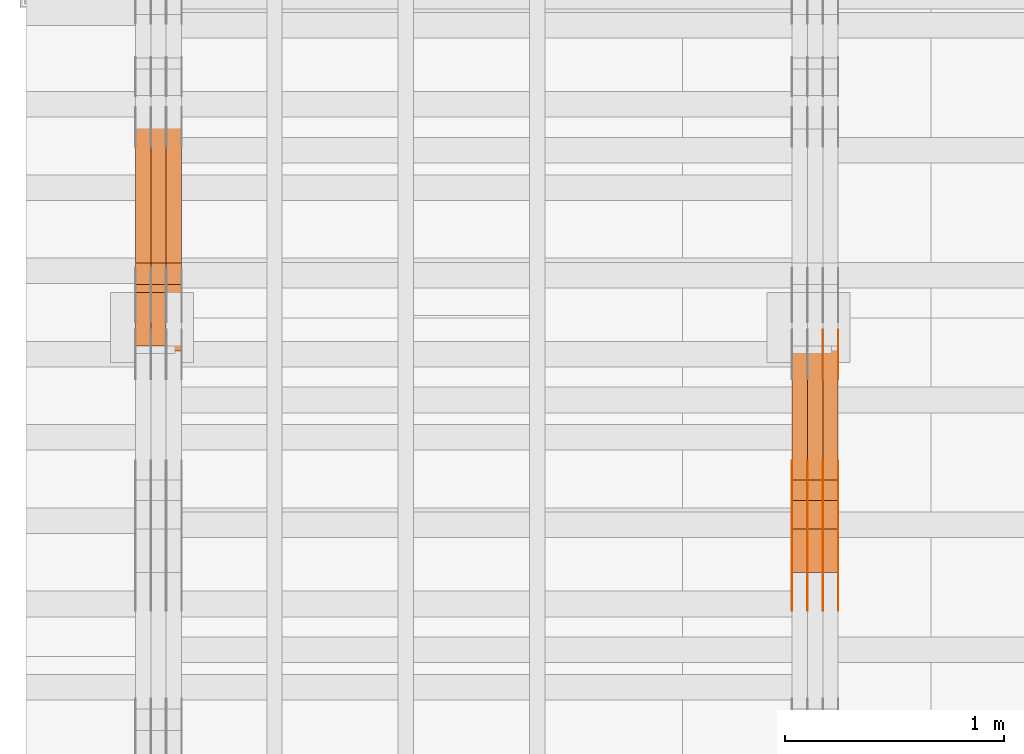
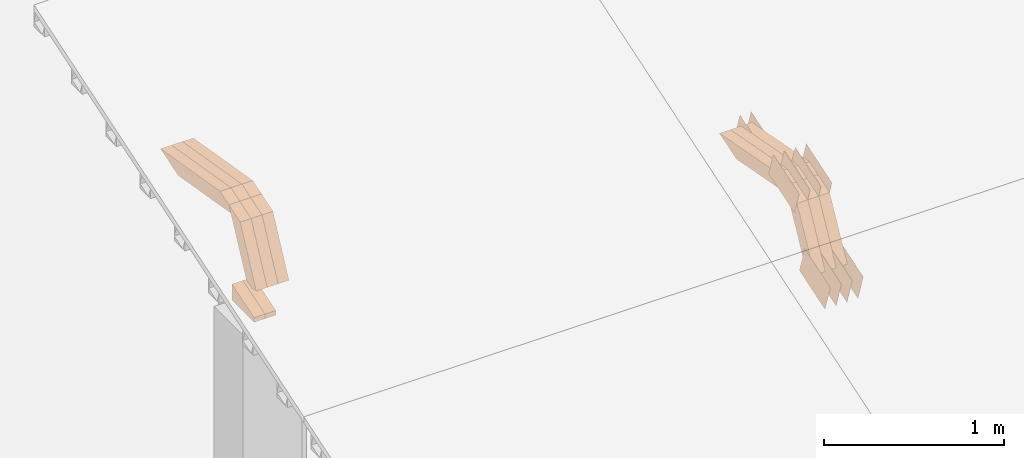
# One storey, part 75 of 385: 28 proxies.
"""IFC2X3 building model written with IfcOpenShell, lengths in millimetres."""

from ifc_helpers import new_model, entity, si_unit, converted_unit, derived_unit, direction, frame, origin, place, context, subcontext, project, spatial, polyline, outline, extrude, source, transform, mapped, material, type_object, type_shapes, element, save


model = new_model("IFC2X3")

# Units and contexts
model_context = context("Model", 3, precision=0.01, world=origin(), true_north=direction((6.12303176911189e-17, 1.0)))
body_context = subcontext(model_context, "Body", "Model", "MODEL_VIEW")
ifc_project = project(units=[si_unit("LENGTHUNIT", "METRE", prefix="MILLI"), si_unit("AREAUNIT", "SQUARE_METRE"), si_unit("VOLUMEUNIT", "CUBIC_METRE"), converted_unit("PLANEANGLEUNIT", "DEGREE", entity("IfcRatioMeasure", 0.0174532925199433), si_unit("PLANEANGLEUNIT", "RADIAN"), dimensions=[0, 0, 0, 0, 0, 0, 0]), si_unit("MASSUNIT", "GRAM", prefix="KILO"), derived_unit("MASSDENSITYUNIT", [(si_unit("MASSUNIT", "GRAM", prefix="KILO"), 1), (si_unit("LENGTHUNIT", "METRE"), -3)]), si_unit("TIMEUNIT", "SECOND"), si_unit("FREQUENCYUNIT", "HERTZ"), si_unit("THERMODYNAMICTEMPERATUREUNIT", "DEGREE_CELSIUS"), derived_unit("THERMALTRANSMITTANCEUNIT", [(si_unit("MASSUNIT", "GRAM", prefix="KILO"), 1), (si_unit("THERMODYNAMICTEMPERATUREUNIT", "KELVIN"), -1), (si_unit("TIMEUNIT", "SECOND"), -3)]), derived_unit("VOLUMETRICFLOWRATEUNIT", [(si_unit("LENGTHUNIT", "METRE"), 3), (si_unit("TIMEUNIT", "SECOND"), -1)]), si_unit("ELECTRICCURRENTUNIT", "AMPERE"), si_unit("ELECTRICVOLTAGEUNIT", "VOLT"), si_unit("POWERUNIT", "WATT"), si_unit("FORCEUNIT", "NEWTON", prefix="KILO"), si_unit("ILLUMINANCEUNIT", "LUX"), si_unit("LUMINOUSFLUXUNIT", "LUMEN"), si_unit("LUMINOUSINTENSITYUNIT", "CANDELA"), derived_unit("USERDEFINED", [(si_unit("MASSUNIT", "GRAM", prefix="KILO"), -1), (si_unit("LENGTHUNIT", "METRE"), -2), (si_unit("TIMEUNIT", "SECOND"), 3), (si_unit("LUMINOUSFLUXUNIT", "LUMEN"), 1)]), derived_unit("LINEARVELOCITYUNIT", [(si_unit("LENGTHUNIT", "METRE"), 1), (si_unit("TIMEUNIT", "SECOND"), -1)]), si_unit("PRESSUREUNIT", "PASCAL"), derived_unit("USERDEFINED", [(si_unit("LENGTHUNIT", "METRE"), -2), (si_unit("MASSUNIT", "GRAM", prefix="KILO"), 1), (si_unit("TIMEUNIT", "SECOND"), -2)])], contexts=[model_context])

# Site, building, storey
site_placement = place(None, origin())
site = spatial("IfcSite", under=ifc_project, at=site_placement, CompositionType="ELEMENT")
building_placement = place(site_placement, origin())
building = spatial("IfcBuilding", under=site, at=building_placement, CompositionType="ELEMENT")
storey_placement = place(building_placement, origin())
storey = spatial("IfcBuildingStorey", under=building, at=storey_placement, Name="Default", CompositionType="ELEMENT", Elevation=0.0)

# Proxies
ifc_material_1 = material(Name="IfcSurfaceStyle #70728")
building_element_proxy_type_1 = type_object("IfcBuildingElementProxyType", PredefinedType="NOTDEFINED", material=ifc_material_1)
shared_shape_1 = source(origin(), body_context, "Body", "SweptSolid", [
    extrude(outline(polyline([(-149.99966632326, -95.9999759039407), (149.999881095801, -95.9999759039407), (150.000557367591, 95.9999759039407), (-150.000772140132, 95.9999759039406), (-149.99966632326, -95.9999759039407)])), frame((150.000557367591, 96.0004291135906, 0.0), z_axis=(0.0, 0.0, 1.0), x_axis=(-1.0, 0.0, 0.0)), (0.0, 0.0, 1.0), 1.29999999999999),
])
type_shapes(building_element_proxy_type_1, [shared_shape_1])
proxy_1_placement = place(building_placement, frame((3386.29999999999, 10934.7734375, 2766.8759765625), z_axis=(-1.0, 0.0, 0.0), x_axis=(0.0, 0.951056516295124, 0.309016994375039)))
element("IfcBuildingElementProxy", 1, at=proxy_1_placement, inside=storey, type_object=building_element_proxy_type_1, material=ifc_material_1, context=body_context, shape_type="MappedRepresentation", body=[
    mapped(shared_shape_1, transform((0.0, 0.0, 0.0), scale=1.0)),
])
ifc_material_2 = material(Name="IfcSurfaceStyle #70671")
building_element_proxy_type_2 = type_object("IfcBuildingElementProxyType", PredefinedType="NOTDEFINED", material=ifc_material_2)
shared_shape_2 = source(origin(), body_context, "Body", "SweptSolid", [
    extrude(outline(polyline([(-149.99966632326, -95.9999759039407), (149.999881095801, -95.9999759039407), (150.000557367591, 95.9999759039407), (-150.000772140132, 95.9999759039406), (-149.99966632326, -95.9999759039407)])), frame((150.000557367591, 96.0004291135906, 0.0), z_axis=(0.0, 0.0, 1.0), x_axis=(-1.0, 0.0, 0.0)), (0.0, 0.0, 1.0), 1.29999999999999),
])
type_shapes(building_element_proxy_type_2, [shared_shape_2])
proxy_2_placement = place(building_placement, frame((3315.0, 10934.7734375, 2766.8759765625), z_axis=(-1.0, 0.0, 0.0), x_axis=(0.0, 0.951056516295124, 0.309016994375039)))
element("IfcBuildingElementProxy", 2, at=proxy_2_placement, inside=storey, type_object=building_element_proxy_type_2, material=ifc_material_2, context=body_context, shape_type="MappedRepresentation", body=[
    mapped(shared_shape_2, transform((0.0, 0.0, 0.0), scale=1.0)),
])
ifc_material_3 = material(Name="IfcSurfaceStyle #70614")
building_element_proxy_type_3 = type_object("IfcBuildingElementProxyType", PredefinedType="NOTDEFINED", material=ifc_material_3)
shared_shape_3 = source(origin(), body_context, "Body", "SweptSolid", [
    extrude(outline(polyline([(-149.99966632326, -95.9999759039407), (149.999881095801, -95.9999759039407), (150.000557367591, 95.9999759039407), (-150.000772140132, 95.9999759039406), (-149.99966632326, -95.9999759039407)])), frame((150.000557367591, 96.0004291135906, 0.0), z_axis=(0.0, 0.0, 1.0), x_axis=(-1.0, 0.0, 0.0)), (0.0, 0.0, 1.0), 1.29999999999999),
])
type_shapes(building_element_proxy_type_3, [shared_shape_3])
proxy_3_placement = place(building_placement, frame((3316.29999999999, 10934.7734375, 2766.8759765625), z_axis=(-1.0, 0.0, 0.0), x_axis=(0.0, 0.951056516295124, 0.309016994375039)))
element("IfcBuildingElementProxy", 3, at=proxy_3_placement, inside=storey, type_object=building_element_proxy_type_3, material=ifc_material_3, context=body_context, shape_type="MappedRepresentation", body=[
    mapped(shared_shape_3, transform((0.0, 0.0, 0.0), scale=1.0)),
])
ifc_material_4 = material(Name="IfcSurfaceStyle #70557")
building_element_proxy_type_4 = type_object("IfcBuildingElementProxyType", PredefinedType="NOTDEFINED", material=ifc_material_4)
shared_shape_4 = source(origin(), body_context, "Body", "SweptSolid", [
    extrude(outline(polyline([(-149.99966632326, -95.9999759039407), (149.999881095801, -95.9999759039407), (150.000557367591, 95.9999759039407), (-150.000772140132, 95.9999759039406), (-149.99966632326, -95.9999759039407)])), frame((150.000557367591, 96.0004291135906, 0.0), z_axis=(0.0, 0.0, 1.0), x_axis=(-1.0, 0.0, 0.0)), (0.0, 0.0, 1.0), 1.29999999999998),
])
type_shapes(building_element_proxy_type_4, [shared_shape_4])
proxy_4_placement = place(building_placement, frame((3245.0, 10934.7734375, 2766.8759765625), z_axis=(-1.0, 0.0, 0.0), x_axis=(0.0, 0.951056516295124, 0.309016994375039)))
element("IfcBuildingElementProxy", 4, at=proxy_4_placement, inside=storey, type_object=building_element_proxy_type_4, material=ifc_material_4, context=body_context, shape_type="MappedRepresentation", body=[
    mapped(shared_shape_4, transform((0.0, 0.0, 0.0), scale=1.0)),
])
ifc_material_5 = material(Name="IfcSurfaceStyle #70500")
building_element_proxy_type_5 = type_object("IfcBuildingElementProxyType", PredefinedType="NOTDEFINED", material=ifc_material_5)
shared_shape_5 = source(origin(), body_context, "Body", "SweptSolid", [
    extrude(outline(polyline([(-149.99966632326, -95.9999759039407), (149.999881095801, -95.9999759039407), (150.000557367591, 95.9999759039407), (-150.000772140132, 95.9999759039406), (-149.99966632326, -95.9999759039407)])), frame((150.000557367591, 96.0004291135906, 0.0), z_axis=(0.0, 0.0, 1.0), x_axis=(-1.0, 0.0, 0.0)), (0.0, 0.0, 1.0), 1.29999999999998),
])
type_shapes(building_element_proxy_type_5, [shared_shape_5])
proxy_5_placement = place(building_placement, frame((3246.29999999999, 10934.7734375, 2766.8759765625), z_axis=(-1.0, 0.0, 0.0), x_axis=(0.0, 0.951056516295124, 0.309016994375039)))
element("IfcBuildingElementProxy", 5, at=proxy_5_placement, inside=storey, type_object=building_element_proxy_type_5, material=ifc_material_5, context=body_context, shape_type="MappedRepresentation", body=[
    mapped(shared_shape_5, transform((0.0, 0.0, 0.0), scale=1.0)),
])
ifc_material_6 = material(Name="IfcSurfaceStyle #70443")
building_element_proxy_type_6 = type_object("IfcBuildingElementProxyType", PredefinedType="NOTDEFINED", material=ifc_material_6)
shared_shape_6 = source(origin(), body_context, "Body", "SweptSolid", [
    extrude(outline(polyline([(-149.99966632326, -95.9999759039407), (149.999881095801, -95.9999759039407), (150.000557367591, 95.9999759039407), (-150.000772140132, 95.9999759039406), (-149.99966632326, -95.9999759039407)])), frame((150.000557367591, 96.0004291135906, 0.0), z_axis=(0.0, 0.0, 1.0), x_axis=(-1.0, 0.0, 0.0)), (0.0, 0.0, 1.0), 1.29999999999998),
])
type_shapes(building_element_proxy_type_6, [shared_shape_6])
proxy_6_placement = place(building_placement, frame((3175.0, 10934.7734375, 2766.8759765625), z_axis=(-1.0, 0.0, 0.0), x_axis=(0.0, 0.951056516295124, 0.309016994375039)))
element("IfcBuildingElementProxy", 6, at=proxy_6_placement, inside=storey, type_object=building_element_proxy_type_6, material=ifc_material_6, context=body_context, shape_type="MappedRepresentation", body=[
    mapped(shared_shape_6, transform((0.0, 0.0, 0.0), scale=1.0)),
])
ifc_material_7 = material(Name="IfcSurfaceStyle #69360")
building_element_proxy_type_7 = type_object("IfcBuildingElementProxyType", PredefinedType="NOTDEFINED", material=ifc_material_7)
shared_shape_7 = source(origin(), body_context, "Body", "SweptSolid", [
    extrude(outline(polyline([(-99.9997874178038, -60.0000528641967), (99.9998102700997, -60.0000528641967), (99.9998251396068, 60.0000528641967), (-99.9998479919027, 60.0000528641967), (-99.9997874178038, -60.0000528641967)])), frame((99.9999918898597, 60.0000528641967, 0.0), z_axis=(0.0, 0.0, 1.0), x_axis=(-1.0, 0.0, 0.0)), (0.0, 0.0, 1.0), 1.3),
])
type_shapes(building_element_proxy_type_7, [shared_shape_7])
proxy_7_placement = place(building_placement, frame((3386.29999999999, 11991.9568177725, 3072.52282247925), z_axis=(-1.0, 0.0, 0.0), x_axis=(0.0, 0.951056516295124, 0.309016994375039)))
element("IfcBuildingElementProxy", 7, at=proxy_7_placement, inside=storey, type_object=building_element_proxy_type_7, material=ifc_material_7, context=body_context, shape_type="MappedRepresentation", body=[
    mapped(shared_shape_7, transform((0.0, 0.0, 0.0), scale=1.0)),
])
ifc_material_8 = material(Name="IfcSurfaceStyle #69303")
building_element_proxy_type_8 = type_object("IfcBuildingElementProxyType", PredefinedType="NOTDEFINED", material=ifc_material_8)
shared_shape_8 = source(origin(), body_context, "Body", "SweptSolid", [
    extrude(outline(polyline([(-99.9997874178038, -60.0000528641967), (99.9998102700997, -60.0000528641967), (99.9998251396068, 60.0000528641967), (-99.9998479919027, 60.0000528641967), (-99.9997874178038, -60.0000528641967)])), frame((99.9999918898597, 60.0000528641967, 0.0), z_axis=(0.0, 0.0, 1.0), x_axis=(-1.0, 0.0, 0.0)), (0.0, 0.0, 1.0), 1.3),
])
type_shapes(building_element_proxy_type_8, [shared_shape_8])
proxy_8_placement = place(building_placement, frame((3315.0, 11991.9568177725, 3072.52282247925), z_axis=(-1.0, 0.0, 0.0), x_axis=(0.0, 0.951056516295124, 0.309016994375039)))
element("IfcBuildingElementProxy", 8, at=proxy_8_placement, inside=storey, type_object=building_element_proxy_type_8, material=ifc_material_8, context=body_context, shape_type="MappedRepresentation", body=[
    mapped(shared_shape_8, transform((0.0, 0.0, 0.0), scale=1.0)),
])
ifc_material_9 = material(Name="IfcSurfaceStyle #61152")
building_element_proxy_type_9 = type_object("IfcBuildingElementProxyType", PredefinedType="NOTDEFINED", material=ifc_material_9)
shared_shape_9 = source(origin(), body_context, "Body", "SweptSolid", [
    extrude(outline(polyline([(-150.000273478628, -84.0002987844282), (149.999198496832, -84.0002987844282), (150.000273478627, 84.0002987844282), (-149.999198496831, 84.0002987844282), (-150.000273478628, -84.0002987844282)])), frame((150.000273478627, 84.0002987844282, 0.0), z_axis=(0.0, 0.0, 1.0), x_axis=(-1.0, 0.0, 0.0)), (0.0, 0.0, 1.0), 1.29999999999999),
])
type_shapes(building_element_proxy_type_9, [shared_shape_9])
proxy_9_placement = place(building_placement, frame((3386.29999999999, 11283.0116722926, 3194.09682266857), z_axis=(-1.0, 0.0, 0.0), x_axis=(0.0, 0.951056516295154, 0.309016994374948)))
element("IfcBuildingElementProxy", 9, at=proxy_9_placement, inside=storey, type_object=building_element_proxy_type_9, material=ifc_material_9, context=body_context, shape_type="MappedRepresentation", body=[
    mapped(shared_shape_9, transform((0.0, 0.0, 0.0), scale=1.0)),
])
ifc_material_10 = material(Name="IfcSurfaceStyle #61095")
building_element_proxy_type_10 = type_object("IfcBuildingElementProxyType", PredefinedType="NOTDEFINED", material=ifc_material_10)
shared_shape_10 = source(origin(), body_context, "Body", "SweptSolid", [
    extrude(outline(polyline([(-150.000273478628, -84.0002987844282), (149.999198496832, -84.0002987844282), (150.000273478627, 84.0002987844282), (-149.999198496831, 84.0002987844282), (-150.000273478628, -84.0002987844282)])), frame((150.000273478627, 84.0002987844282, 0.0), z_axis=(0.0, 0.0, 1.0), x_axis=(-1.0, 0.0, 0.0)), (0.0, 0.0, 1.0), 1.29999999999999),
])
type_shapes(building_element_proxy_type_10, [shared_shape_10])
proxy_10_placement = place(building_placement, frame((3315.0, 11283.0116722926, 3194.09682266857), z_axis=(-1.0, 0.0, 0.0), x_axis=(0.0, 0.951056516295154, 0.309016994374948)))
element("IfcBuildingElementProxy", 10, at=proxy_10_placement, inside=storey, type_object=building_element_proxy_type_10, material=ifc_material_10, context=body_context, shape_type="MappedRepresentation", body=[
    mapped(shared_shape_10, transform((0.0, 0.0, 0.0), scale=1.0)),
])
ifc_material_11 = material(Name="IfcSurfaceStyle #61038")
building_element_proxy_type_11 = type_object("IfcBuildingElementProxyType", PredefinedType="NOTDEFINED", material=ifc_material_11)
shared_shape_11 = source(origin(), body_context, "Body", "SweptSolid", [
    extrude(outline(polyline([(-150.000273478628, -84.0002987844282), (149.999198496832, -84.0002987844282), (150.000273478627, 84.0002987844282), (-149.999198496831, 84.0002987844282), (-150.000273478628, -84.0002987844282)])), frame((150.000273478627, 84.0002987844282, 0.0), z_axis=(0.0, 0.0, 1.0), x_axis=(-1.0, 0.0, 0.0)), (0.0, 0.0, 1.0), 1.29999999999999),
])
type_shapes(building_element_proxy_type_11, [shared_shape_11])
proxy_11_placement = place(building_placement, frame((3316.29999999999, 11283.0116722926, 3194.09682266857), z_axis=(-1.0, 0.0, 0.0), x_axis=(0.0, 0.951056516295154, 0.309016994374948)))
element("IfcBuildingElementProxy", 11, at=proxy_11_placement, inside=storey, type_object=building_element_proxy_type_11, material=ifc_material_11, context=body_context, shape_type="MappedRepresentation", body=[
    mapped(shared_shape_11, transform((0.0, 0.0, 0.0), scale=1.0)),
])
ifc_material_12 = material(Name="IfcSurfaceStyle #60981")
building_element_proxy_type_12 = type_object("IfcBuildingElementProxyType", PredefinedType="NOTDEFINED", material=ifc_material_12)
shared_shape_12 = source(origin(), body_context, "Body", "SweptSolid", [
    extrude(outline(polyline([(-150.000273478628, -84.0002987844282), (149.999198496832, -84.0002987844282), (150.000273478627, 84.0002987844282), (-149.999198496831, 84.0002987844282), (-150.000273478628, -84.0002987844282)])), frame((150.000273478627, 84.0002987844282, 0.0), z_axis=(0.0, 0.0, 1.0), x_axis=(-1.0, 0.0, 0.0)), (0.0, 0.0, 1.0), 1.29999999999998),
])
type_shapes(building_element_proxy_type_12, [shared_shape_12])
proxy_12_placement = place(building_placement, frame((3245.0, 11283.0116722926, 3194.09682266857), z_axis=(-1.0, 0.0, 0.0), x_axis=(0.0, 0.951056516295154, 0.309016994374948)))
element("IfcBuildingElementProxy", 12, at=proxy_12_placement, inside=storey, type_object=building_element_proxy_type_12, material=ifc_material_12, context=body_context, shape_type="MappedRepresentation", body=[
    mapped(shared_shape_12, transform((0.0, 0.0, 0.0), scale=1.0)),
])
ifc_material_13 = material(Name="IfcSurfaceStyle #60924")
building_element_proxy_type_13 = type_object("IfcBuildingElementProxyType", PredefinedType="NOTDEFINED", material=ifc_material_13)
shared_shape_13 = source(origin(), body_context, "Body", "SweptSolid", [
    extrude(outline(polyline([(-150.000273478628, -84.0002987844282), (149.999198496832, -84.0002987844282), (150.000273478627, 84.0002987844282), (-149.999198496831, 84.0002987844282), (-150.000273478628, -84.0002987844282)])), frame((150.000273478627, 84.0002987844282, 0.0), z_axis=(0.0, 0.0, 1.0), x_axis=(-1.0, 0.0, 0.0)), (0.0, 0.0, 1.0), 1.29999999999998),
])
type_shapes(building_element_proxy_type_13, [shared_shape_13])
proxy_13_placement = place(building_placement, frame((3246.29999999999, 11283.0116722926, 3194.09682266857), z_axis=(-1.0, 0.0, 0.0), x_axis=(0.0, 0.951056516295154, 0.309016994374948)))
element("IfcBuildingElementProxy", 13, at=proxy_13_placement, inside=storey, type_object=building_element_proxy_type_13, material=ifc_material_13, context=body_context, shape_type="MappedRepresentation", body=[
    mapped(shared_shape_13, transform((0.0, 0.0, 0.0), scale=1.0)),
])
ifc_material_14 = material(Name="IfcSurfaceStyle #60867")
building_element_proxy_type_14 = type_object("IfcBuildingElementProxyType", PredefinedType="NOTDEFINED", material=ifc_material_14)
shared_shape_14 = source(origin(), body_context, "Body", "SweptSolid", [
    extrude(outline(polyline([(-150.000273478628, -84.0002987844282), (149.999198496832, -84.0002987844282), (150.000273478627, 84.0002987844282), (-149.999198496831, 84.0002987844282), (-150.000273478628, -84.0002987844282)])), frame((150.000273478627, 84.0002987844282, 0.0), z_axis=(0.0, 0.0, 1.0), x_axis=(-1.0, 0.0, 0.0)), (0.0, 0.0, 1.0), 1.29999999999998),
])
type_shapes(building_element_proxy_type_14, [shared_shape_14])
proxy_14_placement = place(building_placement, frame((3175.0, 11283.0116722926, 3194.09682266857), z_axis=(-1.0, 0.0, 0.0), x_axis=(0.0, 0.951056516295154, 0.309016994374948)))
element("IfcBuildingElementProxy", 14, at=proxy_14_placement, inside=storey, type_object=building_element_proxy_type_14, material=ifc_material_14, context=body_context, shape_type="MappedRepresentation", body=[
    mapped(shared_shape_14, transform((0.0, 0.0, 0.0), scale=1.0)),
])
ifc_material_15 = material(Name="IfcSurfaceStyle #50856")
building_element_proxy_type_15 = type_object("IfcBuildingElementProxyType", Name="T1-W9 50854", PredefinedType="NOTDEFINED", material=ifc_material_15)
shared_shape_15 = source(origin(), body_context, "Body", "SweptSolid", [
    extrude(outline(polyline([(-287.457507623288, -47.5000268597988), (288.590479960635, -47.5000268597988), (273.55062971372, -2.33146189358546e-05), (186.625054999886, 47.5000385171083), (-461.308657050953, 47.5000385171083), (-287.457507623288, -47.5000268597988)])), frame((288.590945855618, 47.5000968036551, 0.0), z_axis=(0.0, 0.0, 1.0), x_axis=(-1.0, 0.0, 0.0)), (0.0, 0.0, 1.0), 70.0),
])
type_shapes(building_element_proxy_type_15, [shared_shape_15])
proxy_15_placement = place(building_placement, frame((3385.0, 11432.1200855376, 3205.63308612017), z_axis=(-1.0, 0.0, 0.0), x_axis=(0.0, 0.982760503514031, -0.184883186722992)))
element("IfcBuildingElementProxy", 15, at=proxy_15_placement, inside=storey, type_object=building_element_proxy_type_15, material=ifc_material_15, Name="T1-W9", context=body_context, shape_type="MappedRepresentation", body=[
    mapped(shared_shape_15, transform((0.0, 0.0, 0.0), scale=1.0)),
])
ifc_material_16 = material(Name="IfcSurfaceStyle #50790")
building_element_proxy_type_16 = type_object("IfcBuildingElementProxyType", Name="T1-W9 50788", PredefinedType="NOTDEFINED", material=ifc_material_16)
shared_shape_16 = source(origin(), body_context, "Body", "SweptSolid", [
    extrude(outline(polyline([(-287.457507623288, -47.5000268597988), (288.590479960635, -47.5000268597988), (273.55062971372, -2.33146189358546e-05), (186.625054999886, 47.5000385171083), (-461.308657050953, 47.5000385171083), (-287.457507623288, -47.5000268597988)])), frame((288.590945855618, 47.5000968036551, 0.0), z_axis=(0.0, 0.0, 1.0), x_axis=(-1.0, 0.0, 0.0)), (0.0, 0.0, 1.0), 70.0),
])
type_shapes(building_element_proxy_type_16, [shared_shape_16])
proxy_16_placement = place(building_placement, frame((3315.0, 11432.1200855376, 3205.63308612017), z_axis=(-1.0, 0.0, 0.0), x_axis=(0.0, 0.982760503514031, -0.184883186722992)))
element("IfcBuildingElementProxy", 16, at=proxy_16_placement, inside=storey, type_object=building_element_proxy_type_16, material=ifc_material_16, Name="T1-W9", context=body_context, shape_type="MappedRepresentation", body=[
    mapped(shared_shape_16, transform((0.0, 0.0, 0.0), scale=1.0)),
])
ifc_material_17 = material(Name="IfcSurfaceStyle #50724")
building_element_proxy_type_17 = type_object("IfcBuildingElementProxyType", Name="T1-W9 50722", PredefinedType="NOTDEFINED", material=ifc_material_17)
shared_shape_17 = source(origin(), body_context, "Body", "SweptSolid", [
    extrude(outline(polyline([(-287.457507623288, -47.5000268597988), (288.590479960635, -47.5000268597988), (273.55062971372, -2.33146189358546e-05), (186.625054999886, 47.5000385171083), (-461.308657050953, 47.5000385171083), (-287.457507623288, -47.5000268597988)])), frame((288.590945855618, 47.5000968036551, 0.0), z_axis=(0.0, 0.0, 1.0), x_axis=(-1.0, 0.0, 0.0)), (0.0, 0.0, 1.0), 70.0),
])
type_shapes(building_element_proxy_type_17, [shared_shape_17])
proxy_17_placement = place(building_placement, frame((3245.0, 11432.1200855376, 3205.63308612017), z_axis=(-1.0, 0.0, 0.0), x_axis=(0.0, 0.982760503514031, -0.184883186722992)))
element("IfcBuildingElementProxy", 17, at=proxy_17_placement, inside=storey, type_object=building_element_proxy_type_17, material=ifc_material_17, Name="T1-W9", context=body_context, shape_type="MappedRepresentation", body=[
    mapped(shared_shape_17, transform((0.0, 0.0, 0.0), scale=1.0)),
])
ifc_material_18 = material(Name="IfcSurfaceStyle #50460")
building_element_proxy_type_18 = type_object("IfcBuildingElementProxyType", Name="T1-W32 50458", PredefinedType="NOTDEFINED", material=ifc_material_18)
shared_shape_18 = source(origin(), body_context, "Body", "SweptSolid", [
    extrude(outline(polyline([(-312.414547135921, -47.5000544873059), (136.677011757652, -47.5000544873059), (186.250996577889, 0.000369497452627243), (202.753116295831, 47.4998697385796), (-213.26657749545, 47.4998697385796), (-312.414547135921, -47.5000544873059)])), frame((202.753376481939, 47.5001296985553, 0.0), z_axis=(0.0, 0.0, 1.0), x_axis=(-1.0, 0.0, 0.0)), (0.0, 0.0, 1.0), 70.0),
])
type_shapes(building_element_proxy_type_18, [shared_shape_18])
proxy_18_placement = place(building_placement, frame((3385.0, 11110.7808979007, 2747.18129017315), z_axis=(-1.0, 0.0, 0.0), x_axis=(0.0, 0.472919689385906, 0.881105537033526)))
element("IfcBuildingElementProxy", 18, at=proxy_18_placement, inside=storey, type_object=building_element_proxy_type_18, material=ifc_material_18, Name="T1-W32", context=body_context, shape_type="MappedRepresentation", body=[
    mapped(shared_shape_18, transform((0.0, 0.0, 0.0), scale=1.0)),
])
ifc_material_19 = material(Name="IfcSurfaceStyle #50394")
building_element_proxy_type_19 = type_object("IfcBuildingElementProxyType", Name="T1-W32 50392", PredefinedType="NOTDEFINED", material=ifc_material_19)
shared_shape_19 = source(origin(), body_context, "Body", "SweptSolid", [
    extrude(outline(polyline([(-312.414547135921, -47.5000544873059), (136.677011757652, -47.5000544873059), (186.250996577889, 0.000369497452627243), (202.753116295831, 47.4998697385796), (-213.26657749545, 47.4998697385796), (-312.414547135921, -47.5000544873059)])), frame((202.753376481939, 47.5001296985553, 0.0), z_axis=(0.0, 0.0, 1.0), x_axis=(-1.0, 0.0, 0.0)), (0.0, 0.0, 1.0), 70.0),
])
type_shapes(building_element_proxy_type_19, [shared_shape_19])
proxy_19_placement = place(building_placement, frame((3315.0, 11110.7808979007, 2747.18129017315), z_axis=(-1.0, 0.0, 0.0), x_axis=(0.0, 0.472919689385906, 0.881105537033526)))
element("IfcBuildingElementProxy", 19, at=proxy_19_placement, inside=storey, type_object=building_element_proxy_type_19, material=ifc_material_19, Name="T1-W32", context=body_context, shape_type="MappedRepresentation", body=[
    mapped(shared_shape_19, transform((0.0, 0.0, 0.0), scale=1.0)),
])
ifc_material_20 = material(Name="IfcSurfaceStyle #50328")
building_element_proxy_type_20 = type_object("IfcBuildingElementProxyType", Name="T1-W32 50326", PredefinedType="NOTDEFINED", material=ifc_material_20)
shared_shape_20 = source(origin(), body_context, "Body", "SweptSolid", [
    extrude(outline(polyline([(-312.414547135921, -47.5000544873059), (136.677011757652, -47.5000544873059), (186.250996577889, 0.000369497452627243), (202.753116295831, 47.4998697385796), (-213.26657749545, 47.4998697385796), (-312.414547135921, -47.5000544873059)])), frame((202.753376481939, 47.5001296985553, 0.0), z_axis=(0.0, 0.0, 1.0), x_axis=(-1.0, 0.0, 0.0)), (0.0, 0.0, 1.0), 70.0),
])
type_shapes(building_element_proxy_type_20, [shared_shape_20])
proxy_20_placement = place(building_placement, frame((3245.0, 11110.7808979007, 2747.18129017315), z_axis=(-1.0, 0.0, 0.0), x_axis=(0.0, 0.472919689385906, 0.881105537033526)))
element("IfcBuildingElementProxy", 20, at=proxy_20_placement, inside=storey, type_object=building_element_proxy_type_20, material=ifc_material_20, Name="T1-W32", context=body_context, shape_type="MappedRepresentation", body=[
    mapped(shared_shape_20, transform((0.0, 0.0, 0.0), scale=1.0)),
])
ifc_material_21 = material(Name="IfcSurfaceStyle #18887")
building_element_proxy_type_21 = type_object("IfcBuildingElementProxyType", Name="T1-E1 18885", PredefinedType="NOTDEFINED", material=ifc_material_21)
shared_shape_21 = source(origin(), body_context, "Body", "SweptSolid", [
    extrude(outline(polyline([(-75.1378173828004, -122.500000000005), (35.3350830078246, -122.500000000005), (35.3350830078004, 122.500000000005), (4.46765136717545, 122.500000000005), (-75.1378173828004, -122.500000000005)])), frame((35.3350830078246, 122.500000104877, 0.0), z_axis=(0.0, 0.0, 1.0), x_axis=(-1.0, 0.0, 0.0)), (0.0, 0.0, 1.0), 70.0),
])
type_shapes(building_element_proxy_type_21, [shared_shape_21])
proxy_21_placement = place(building_placement, frame((315.0, 12145.0, 2849.54565429685), z_axis=(-1.0, 0.0, 0.0), x_axis=(0.0, 0.0, 1.0)))
element("IfcBuildingElementProxy", 21, at=proxy_21_placement, inside=storey, type_object=building_element_proxy_type_21, material=ifc_material_21, Name="T1-E1", context=body_context, shape_type="MappedRepresentation", body=[
    mapped(shared_shape_21, transform((0.0, 0.0, 0.0), scale=1.0)),
])
ifc_material_22 = material(Name="IfcSurfaceStyle #18830")
building_element_proxy_type_22 = type_object("IfcBuildingElementProxyType", Name="T1-E1 18828", PredefinedType="NOTDEFINED", material=ifc_material_22)
shared_shape_22 = source(origin(), body_context, "Body", "SweptSolid", [
    extrude(outline(polyline([(-75.1378173828004, -122.500000000005), (35.3350830078246, -122.500000000005), (35.3350830078004, 122.500000000005), (4.46765136717545, 122.500000000005), (-75.1378173828004, -122.500000000005)])), frame((35.3350830078246, 122.500000104877, 0.0), z_axis=(0.0, 0.0, 1.0), x_axis=(-1.0, 0.0, 0.0)), (0.0, 0.0, 1.0), 70.0),
])
type_shapes(building_element_proxy_type_22, [shared_shape_22])
proxy_22_placement = place(building_placement, frame((245.0, 12145.0, 2849.54565429685), z_axis=(-1.0, 0.0, 0.0), x_axis=(0.0, 0.0, 1.0)))
element("IfcBuildingElementProxy", 22, at=proxy_22_placement, inside=storey, type_object=building_element_proxy_type_22, material=ifc_material_22, Name="T1-E1", context=body_context, shape_type="MappedRepresentation", body=[
    mapped(shared_shape_22, transform((0.0, 0.0, 0.0), scale=1.0)),
])
ifc_material_23 = material(Name="IfcSurfaceStyle #17216")
building_element_proxy_type_23 = type_object("IfcBuildingElementProxyType", Name="T1-W7 17214", PredefinedType="NOTDEFINED", material=ifc_material_23)
shared_shape_23 = source(origin(), body_context, "Body", "SweptSolid", [
    extrude(outline(polyline([(-296.174043820986, -47.5000676566704), (297.841254477443, -47.5000676566704), (283.518570346415, -7.10254316533821e-06), (192.674144473719, 47.500071207942), (-477.859925476591, 47.500071207942), (-296.174043820986, -47.5000676566704)])), frame((297.841254477443, 47.5000816097442, 0.0), z_axis=(0.0, 0.0, 1.0), x_axis=(-1.0, 0.0, 0.0)), (0.0, 0.0, 1.0), 70.0),
])
type_shapes(building_element_proxy_type_23, [shared_shape_23])
proxy_23_placement = place(building_placement, frame((385.0, 12419.2991208897, 3526.2136755972), z_axis=(-1.0, 0.0, 0.0), x_axis=(0.0, 0.985983815111804, -0.166840991178939)))
element("IfcBuildingElementProxy", 23, at=proxy_23_placement, inside=storey, type_object=building_element_proxy_type_23, material=ifc_material_23, Name="T1-W7", context=body_context, shape_type="MappedRepresentation", body=[
    mapped(shared_shape_23, transform((0.0, 0.0, 0.0), scale=1.0)),
])
ifc_material_24 = material(Name="IfcSurfaceStyle #17150")
building_element_proxy_type_24 = type_object("IfcBuildingElementProxyType", Name="T1-W7 17148", PredefinedType="NOTDEFINED", material=ifc_material_24)
shared_shape_24 = source(origin(), body_context, "Body", "SweptSolid", [
    extrude(outline(polyline([(-296.174043820986, -47.5000676566704), (297.841254477443, -47.5000676566704), (283.518570346415, -7.10254316533821e-06), (192.674144473719, 47.500071207942), (-477.859925476591, 47.500071207942), (-296.174043820986, -47.5000676566704)])), frame((297.841254477443, 47.5000816097442, 0.0), z_axis=(0.0, 0.0, 1.0), x_axis=(-1.0, 0.0, 0.0)), (0.0, 0.0, 1.0), 70.0),
])
type_shapes(building_element_proxy_type_24, [shared_shape_24])
proxy_24_placement = place(building_placement, frame((315.0, 12419.2991208897, 3526.2136755972), z_axis=(-1.0, 0.0, 0.0), x_axis=(0.0, 0.985983815111804, -0.166840991178939)))
element("IfcBuildingElementProxy", 24, at=proxy_24_placement, inside=storey, type_object=building_element_proxy_type_24, material=ifc_material_24, Name="T1-W7", context=body_context, shape_type="MappedRepresentation", body=[
    mapped(shared_shape_24, transform((0.0, 0.0, 0.0), scale=1.0)),
])
ifc_material_25 = material(Name="IfcSurfaceStyle #17084")
building_element_proxy_type_25 = type_object("IfcBuildingElementProxyType", Name="T1-W7 17082", PredefinedType="NOTDEFINED", material=ifc_material_25)
shared_shape_25 = source(origin(), body_context, "Body", "SweptSolid", [
    extrude(outline(polyline([(-296.174043820986, -47.5000676566704), (297.841254477443, -47.5000676566704), (283.518570346415, -7.10254316533821e-06), (192.674144473719, 47.500071207942), (-477.859925476591, 47.500071207942), (-296.174043820986, -47.5000676566704)])), frame((297.841254477443, 47.5000816097442, 0.0), z_axis=(0.0, 0.0, 1.0), x_axis=(-1.0, 0.0, 0.0)), (0.0, 0.0, 1.0), 70.0),
])
type_shapes(building_element_proxy_type_25, [shared_shape_25])
proxy_25_placement = place(building_placement, frame((245.0, 12419.2991208897, 3526.2136755972), z_axis=(-1.0, 0.0, 0.0), x_axis=(0.0, 0.985983815111804, -0.166840991178939)))
element("IfcBuildingElementProxy", 25, at=proxy_25_placement, inside=storey, type_object=building_element_proxy_type_25, material=ifc_material_25, Name="T1-W7", context=body_context, shape_type="MappedRepresentation", body=[
    mapped(shared_shape_25, transform((0.0, 0.0, 0.0), scale=1.0)),
])
ifc_material_26 = material(Name="IfcSurfaceStyle #16820")
building_element_proxy_type_26 = type_object("IfcBuildingElementProxyType", Name="T1-W36 16818", PredefinedType="NOTDEFINED", material=ifc_material_26)
shared_shape_26 = source(origin(), body_context, "Body", "SweptSolid", [
    extrude(outline(polyline([(-300.714670922549, -47.4998881108849), (134.031527004269, -47.499888110885), (180.52054953879, -0.000136170977331764), (193.89900152221, 47.500563476126), (-207.736407142719, 47.4993489166213), (-300.714670922549, -47.4998881108849)])), frame((193.899145164686, 47.5001861375837, 0.0), z_axis=(0.0, 0.0, 1.0), x_axis=(-1.0, 3.02403492980632e-06, 0.0)), (0.0, 0.0, 1.0), 70.0),
])
type_shapes(building_element_proxy_type_26, [shared_shape_26])
proxy_26_placement = place(building_placement, frame((385.0, 12120.5935627532, 3076.1128858536), z_axis=(-1.0, 0.0, 0.0), x_axis=(0.0, 0.444384650266842, 0.895836080210669)))
element("IfcBuildingElementProxy", 26, at=proxy_26_placement, inside=storey, type_object=building_element_proxy_type_26, material=ifc_material_26, Name="T1-W36", context=body_context, shape_type="MappedRepresentation", body=[
    mapped(shared_shape_26, transform((0.0, 0.0, 0.0), scale=1.0)),
])
ifc_material_27 = material(Name="IfcSurfaceStyle #16754")
building_element_proxy_type_27 = type_object("IfcBuildingElementProxyType", Name="T1-W36 16752", PredefinedType="NOTDEFINED", material=ifc_material_27)
shared_shape_27 = source(origin(), body_context, "Body", "SweptSolid", [
    extrude(outline(polyline([(-300.714670922549, -47.4998881108849), (134.031527004269, -47.499888110885), (180.52054953879, -0.000136170977331764), (193.89900152221, 47.500563476126), (-207.736407142719, 47.4993489166213), (-300.714670922549, -47.4998881108849)])), frame((193.899145164686, 47.5001861375837, 0.0), z_axis=(0.0, 0.0, 1.0), x_axis=(-1.0, 3.02403492980632e-06, 0.0)), (0.0, 0.0, 1.0), 70.0),
])
type_shapes(building_element_proxy_type_27, [shared_shape_27])
proxy_27_placement = place(building_placement, frame((315.0, 12120.5935627532, 3076.1128858536), z_axis=(-1.0, 0.0, 0.0), x_axis=(0.0, 0.444384650266842, 0.895836080210669)))
element("IfcBuildingElementProxy", 27, at=proxy_27_placement, inside=storey, type_object=building_element_proxy_type_27, material=ifc_material_27, Name="T1-W36", context=body_context, shape_type="MappedRepresentation", body=[
    mapped(shared_shape_27, transform((0.0, 0.0, 0.0), scale=1.0)),
])
ifc_material_28 = material(Name="IfcSurfaceStyle #16688")
building_element_proxy_type_28 = type_object("IfcBuildingElementProxyType", Name="T1-W36 16686", PredefinedType="NOTDEFINED", material=ifc_material_28)
shared_shape_28 = source(origin(), body_context, "Body", "SweptSolid", [
    extrude(outline(polyline([(-300.714670922549, -47.4998881108849), (134.031527004269, -47.499888110885), (180.52054953879, -0.000136170977331764), (193.89900152221, 47.500563476126), (-207.736407142719, 47.4993489166213), (-300.714670922549, -47.4998881108849)])), frame((193.899145164686, 47.5001861375837, 0.0), z_axis=(0.0, 0.0, 1.0), x_axis=(-1.0, 3.02403492980632e-06, 0.0)), (0.0, 0.0, 1.0), 70.0),
])
type_shapes(building_element_proxy_type_28, [shared_shape_28])
proxy_28_placement = place(building_placement, frame((245.0, 12120.5935627532, 3076.1128858536), z_axis=(-1.0, 0.0, 0.0), x_axis=(0.0, 0.444384650266842, 0.895836080210669)))
element("IfcBuildingElementProxy", 28, at=proxy_28_placement, inside=storey, type_object=building_element_proxy_type_28, material=ifc_material_28, Name="T1-W36", context=body_context, shape_type="MappedRepresentation", body=[
    mapped(shared_shape_28, transform((0.0, 0.0, 0.0), scale=1.0)),
])

save(model, "model.ifc")
